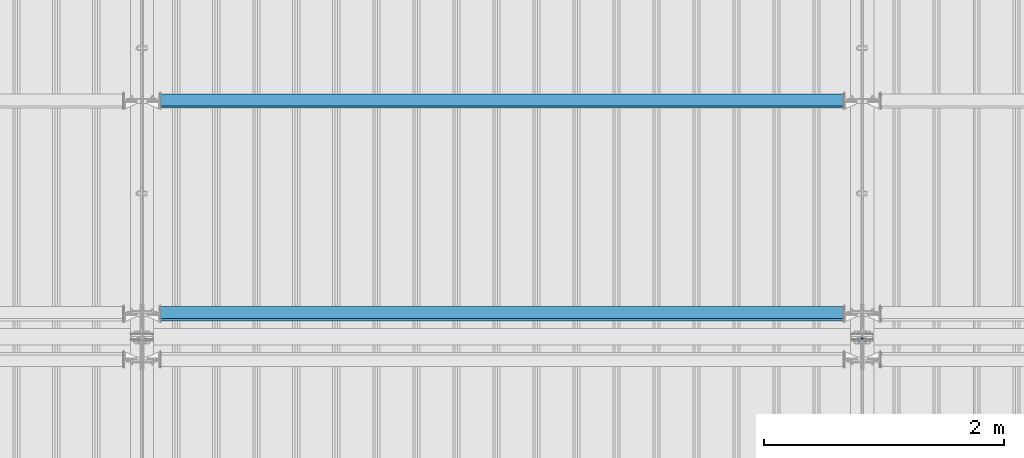
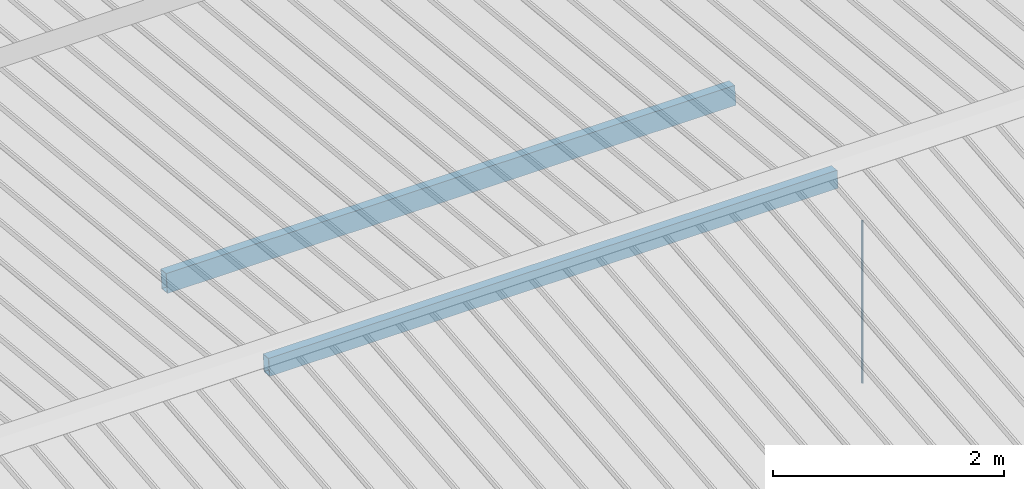
# One storey, part 259 of 709: 3 beams, 3 elements without a shape of their own.
"""IFC4 building model written with IfcOpenShell, lengths in millimetres."""

from ifc_helpers import new_model, si_unit, direction, frame, origin_with_axes, place, context, subcontext, project, spatial, polygons, material, element, aggregate, save


model = new_model("IFC4")

# Units and contexts
model_context = context("Model", 3, precision=0.2, world=origin_with_axes(), true_north=direction((0.0, 1.0)))
body_context = subcontext(model_context, "Body", "Model", "MODEL_VIEW")
ifc_project = project(units=[si_unit("LENGTHUNIT", "METRE", prefix="MILLI"), si_unit("AREAUNIT", "SQUARE_METRE"), si_unit("VOLUMEUNIT", "CUBIC_METRE"), si_unit("MASSUNIT", "GRAM", prefix="KILO"), si_unit("TIMEUNIT", "SECOND"), si_unit("PLANEANGLEUNIT", "RADIAN"), si_unit("SOLIDANGLEUNIT", "STERADIAN"), si_unit("THERMODYNAMICTEMPERATUREUNIT", "DEGREE_CELSIUS"), si_unit("LUMINOUSINTENSITYUNIT", "LUMEN")], contexts=[model_context])

# Site, building, storey
site_placement = place(None, origin_with_axes())
site = spatial("IfcSite", under=ifc_project, at=site_placement, CompositionType="ELEMENT")
building_placement = place(site_placement, origin_with_axes())
building = spatial("IfcBuilding", under=site, at=building_placement, Name="Undefined", CompositionType="ELEMENT")
storey_placement = place(building_placement, origin_with_axes())
storey = spatial("IfcBuildingStorey", under=building, at=storey_placement, Name="Undefined", CompositionType="ELEMENT", Elevation=0.0)

# Assembly, beam
assembly_1_placement = place(storey_placement, frame((22000.0, 10985.0, 8155.10002), z_axis=(0.0, -1.0, 0.0), x_axis=(0.0, 0.0, -1.0)))
assembly_1 = element("IfcElementAssembly", 1, at=assembly_1_placement, inside=storey)
ifc_material_1 = material(Name="C355-5", Category="STEEL")
beam_1_placement = place(assembly_1_placement, origin_with_axes())
beam_1 = element("IfcBeam", 2, at=beam_1_placement, material=ifc_material_1, ObjectType="437", context=body_context, shape_type="Tessellation", body=[
    polygons([(326.36285, 0.0, 10.0), (326.36285, -2.58819, 9.65926), (2045.1, -2.58819, 9.65926), (2045.1, 0.0, 10.0), (326.36285, -5.0, 8.66025), (2045.1, -5.0, 8.66025), (326.36285, -7.07107, 7.07107), (2045.1, -7.07107, 7.07107), (326.36285, -8.66025, 5.0), (2045.1, -8.66025, 5.0), (326.36285, -9.65926, 2.58819), (2045.1, -9.65926, 2.58819), (326.36285, -10.0, 0.0), (2045.1, -10.0, 0.0), (326.36285, -9.65926, -2.58819), (2045.1, -9.65926, -2.58819), (326.36285, -8.66025, -5.0), (2045.1, -8.66025, -5.0), (326.36285, -7.07107, -7.07107), (2045.1, -7.07107, -7.07107), (326.36285, -5.0, -8.66025), (2045.1, -5.0, -8.66025), (326.36285, -2.58819, -9.65926), (2045.1, -2.58819, -9.65926), (326.36285, 0.0, -10.0), (2045.1, 0.0, -10.0), (326.36285, 2.58819, -9.65926), (2045.1, 2.58819, -9.65926), (326.36285, 5.0, -8.66025), (2045.1, 5.0, -8.66025), (326.36285, 7.07107, -7.07107), (2045.1, 7.07107, -7.07107), (326.36285, 8.66025, -5.0), (2045.1, 8.66025, -5.0), (326.36285, 9.65926, -2.58819), (2045.1, 9.65926, -2.58819), (326.36285, 10.0, 0.0), (2045.1, 10.0, 0.0), (326.36285, 9.65926, 2.58819), (2045.1, 9.65926, 2.58819), (326.36285, 8.66025, 5.0), (2045.1, 8.66025, 5.0), (326.36285, 7.07107, 7.07107), (2045.1, 7.07107, 7.07107), (326.36285, 5.0, 8.66025), (2045.1, 5.0, 8.66025), (326.36285, 2.58819, 9.65926), (2045.1, 2.58819, 9.65926)], [[[1, 2, 3, 4]], [[2, 5, 6, 3]], [[5, 7, 8, 6]], [[7, 9, 10, 8]], [[9, 11, 12, 10]], [[11, 13, 14, 12]], [[13, 15, 16, 14]], [[15, 17, 18, 16]], [[17, 19, 20, 18]], [[19, 21, 22, 20]], [[21, 23, 24, 22]], [[23, 25, 26, 24]], [[25, 27, 28, 26]], [[27, 29, 30, 28]], [[29, 31, 32, 30]], [[31, 33, 34, 32]], [[33, 35, 36, 34]], [[35, 37, 38, 36]], [[37, 39, 40, 38]], [[39, 41, 42, 40]], [[41, 43, 44, 42]], [[43, 45, 46, 44]], [[45, 47, 48, 46]], [[47, 1, 4, 48]], [[6, 8, 10, 12, 14, 16, 18, 20, 22, 24, 26, 28, 30, 32, 34, 36, 38, 40, 42, 44, 46, 48, 4, 3]], [[47, 45, 43, 41, 39, 37, 35, 33, 31, 29, 27, 25, 23, 21, 19, 17, 15, 13, 11, 9, 7, 5, 2, 1]]], closed=True),
])
aggregate(assembly_1, [beam_1])

assembly_2_placement = place(storey_placement, frame((22000.0, 11191.04467, 8219.40952), z_axis=(0.0, -0.9950371902, 0.099503719), x_axis=(-1.0, 0.0, 0.0)))
assembly_2 = element("IfcElementAssembly", 3, at=assembly_2_placement, inside=storey)
ifc_material_2 = material(Name="C355", Category="STEEL")
beam_2_placement = place(assembly_2_placement, origin_with_axes())
beam_2 = element("IfcBeam", 4, at=beam_2_placement, material=ifc_material_2, ObjectType="580", context=body_context, shape_type="Tessellation", body=[
    polygons([(155.0, -86.0, -46.0), (155.0, -86.0, 46.0), (5845.0, -86.0, 46.0), (5845.0, -86.0, -46.0), (155.0, 86.0, 46.0), (5845.0, 86.0, 46.0), (155.0, 86.0, -46.0), (5845.0, 86.0, -46.0), (155.0, -90.0, -50.0), (155.0, 90.0, -50.0), (5845.0, 90.0, -50.0), (5845.0, -90.0, -50.0), (155.0, 90.0, 50.0), (5845.0, 90.0, 50.0), (155.0, -90.0, 50.0), (5845.0, -90.0, 50.0)], [[[1, 2, 3, 4]], [[2, 5, 6, 3]], [[5, 7, 8, 6]], [[7, 1, 4, 8]], [[9, 10, 11, 12]], [[10, 13, 14, 11]], [[13, 15, 16, 14]], [[15, 9, 12, 16]], [[14, 16, 12, 11], [6, 8, 4, 3]], [[15, 13, 10, 9], [7, 5, 2, 1]]], closed=True),
])
aggregate(assembly_2, [beam_2])

assembly_3_placement = place(storey_placement, frame((22000.0, 12963.34988, 8032.12913), z_axis=(0.0, -0.9950371902, 0.099503719), x_axis=(-1.0, 0.0, 0.0)))
assembly_3 = element("IfcElementAssembly", 5, at=assembly_3_placement, inside=storey)
beam_3_placement = place(assembly_3_placement, origin_with_axes())
beam_3 = element("IfcBeam", 6, at=beam_3_placement, material=ifc_material_2, ObjectType="579", context=body_context, shape_type="Tessellation", body=[
    polygons([(155.0, -96.0, -46.0), (155.0, -96.0, 46.0), (5845.0, -96.0, 46.0), (5845.0, -96.0, -46.0), (155.0, 96.0, 46.0), (5845.0, 96.0, 46.0), (155.0, 96.0, -46.0), (5845.0, 96.0, -46.0), (155.0, -100.0, -50.0), (155.0, 100.0, -50.0), (5845.0, 100.0, -50.0), (5845.0, -100.0, -50.0), (155.0, 100.0, 50.0), (5845.0, 100.0, 50.0), (155.0, -100.0, 50.0), (5845.0, -100.0, 50.0)], [[[1, 2, 3, 4]], [[2, 5, 6, 3]], [[5, 7, 8, 6]], [[7, 1, 4, 8]], [[9, 10, 11, 12]], [[10, 13, 14, 11]], [[13, 15, 16, 14]], [[15, 9, 12, 16]], [[14, 16, 12, 11], [6, 8, 4, 3]], [[15, 13, 10, 9], [7, 5, 2, 1]]], closed=True),
])
aggregate(assembly_3, [beam_3])

save(model, "model.ifc")
